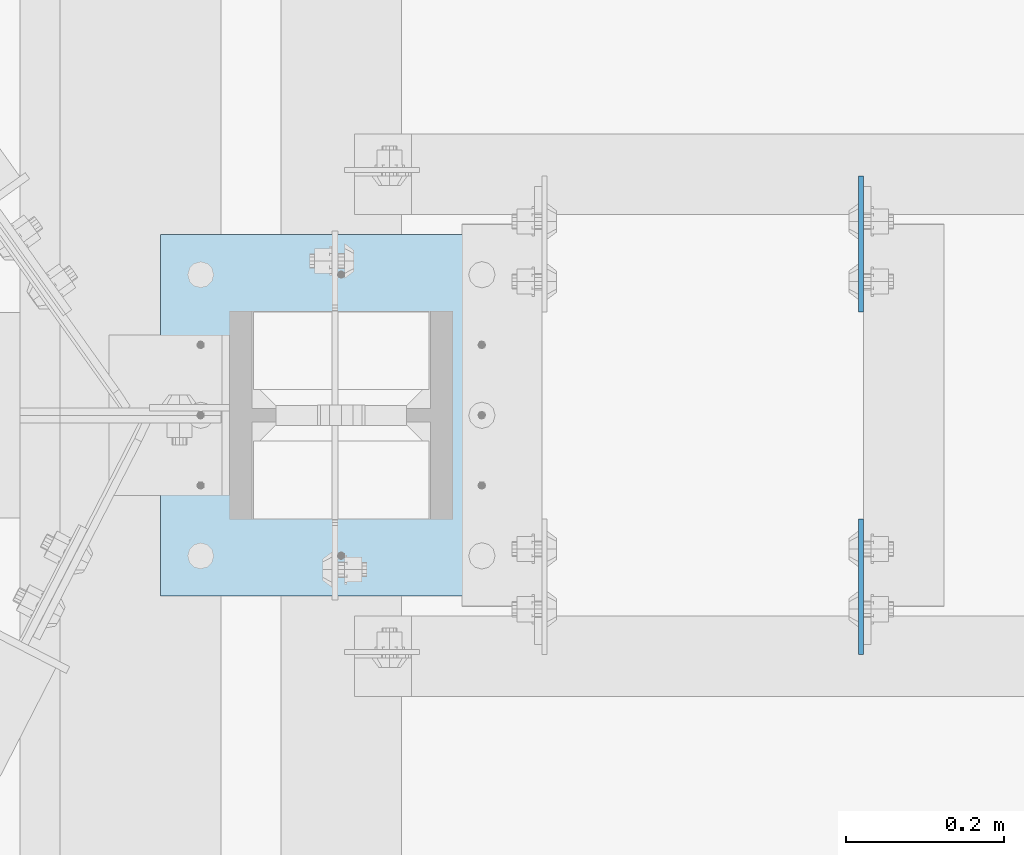
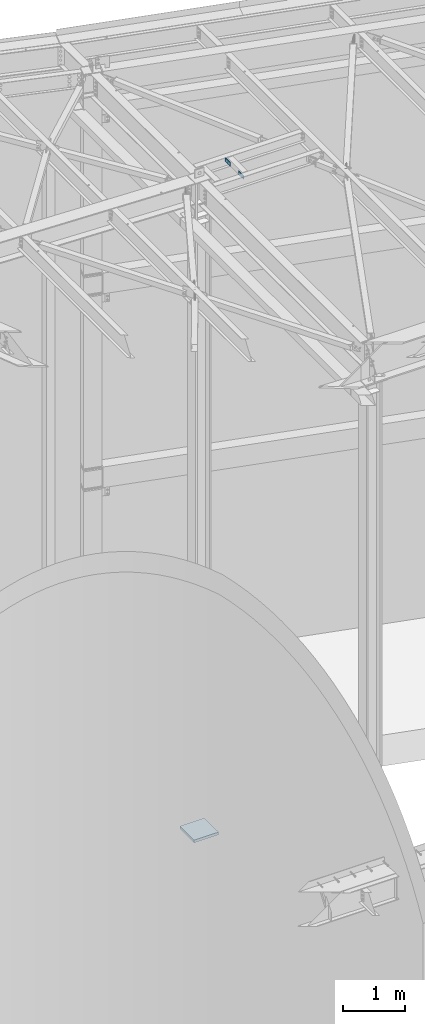
# One storey, part 1662 of 1763: 3 plates, 3 elements without a shape of their own.
"""IFC2X3 building model written with IfcOpenShell, lengths in millimetres."""

from ifc_helpers import new_model, si_unit, frame, origin_with_axes, place, context, subcontext, project, spatial, faceted_brep, material, type_object, element, aggregate, save


model = new_model("IFC2X3")

# Units and contexts
model_context = context("Model", 3, precision=1e-05, world=origin_with_axes())
body_context = subcontext(model_context, "Body", "Model", "MODEL_VIEW")
ifc_project = project(units=[si_unit("LENGTHUNIT", "METRE", prefix="MILLI"), si_unit("AREAUNIT", "SQUARE_METRE"), si_unit("VOLUMEUNIT", "CUBIC_METRE"), si_unit("MASSUNIT", "GRAM", prefix="KILO"), si_unit("TIMEUNIT", "SECOND"), si_unit("PLANEANGLEUNIT", "RADIAN"), si_unit("SOLIDANGLEUNIT", "STERADIAN"), si_unit("THERMODYNAMICTEMPERATUREUNIT", "DEGREE_CELSIUS"), si_unit("LUMINOUSINTENSITYUNIT", "LUMEN")], contexts=[model_context])

# Site, building, storey
site_placement = place(None, origin_with_axes())
site = spatial("IfcSite", under=ifc_project, at=site_placement, CompositionType="ELEMENT")
building_placement = place(site_placement, origin_with_axes())
building = spatial("IfcBuilding", under=site, at=building_placement, Name="Undefined", CompositionType="ELEMENT")
storey_placement = place(building_placement, origin_with_axes())
storey = spatial("IfcBuildingStorey", under=building, at=storey_placement, Name="Undefined", CompositionType="ELEMENT", Elevation=0.0)

# Assembly, plate
assembly_1_placement = place(storey_placement, origin_with_axes())
assembly_1 = element("IfcElementAssembly", 1, at=assembly_1_placement, inside=storey, Name="BEAM", AssemblyPlace="NOTDEFINED", PredefinedType="RIGID_FRAME")
ifc_material = material(Name="STEEL/A36")
plate_type_1 = type_object("IfcPlateType", PredefinedType="NOTDEFINED")
plate_1_placement = place(assembly_1_placement, frame((-39015.0646174483, 63503.96875, 12420.6), z_axis=(0.0, -1.0, 0.0), x_axis=(0.0, 0.0, -1.0)))
plate_1 = element("IfcPlate", 2, at=plate_1_placement, type_object=plate_type_1, material=ifc_material, Name="PLATE", context=body_context, shape_type="Brep", body=[
    faceted_brep([(1.81898940354586e-12, -3.17500000000291, 0.0), (0.0, -3.17500000000291, 171.449996948242), (0.0, 3.17500000000291, 171.449996948242), (-1.81898940354586e-12, 3.17499999997381, 0.0), (76.1999969482422, -3.17500000000291, 171.449996948242), (76.1999969482422, 3.17500000000291, 171.449996948242), (76.1999969482422, -3.17500000000291, 0.0), (76.1999969482422, 3.17500000000291, 0.0)], [[[0, 1, 2, 3]], [[1, 4, 5, 2]], [[4, 6, 7, 5]], [[6, 0, 3, 7]], [[5, 7, 3, 2]], [[6, 4, 1, 0]]]),
])
aggregate(assembly_1, [plate_1])

assembly_2_placement = place(storey_placement, origin_with_axes())
assembly_2 = element("IfcElementAssembly", 3, at=assembly_2_placement, inside=storey, Name="BEAM", AssemblyPlace="NOTDEFINED", PredefinedType="RIGID_FRAME")
plate_2_placement = place(assembly_2_placement, frame((-39015.0646174483, 62899.13125, 12420.6), z_axis=(0.0, 1.0, 0.0), x_axis=(0.0, 0.0, -1.0)))
plate_2 = element("IfcPlate", 4, at=plate_2_placement, type_object=plate_type_1, material=ifc_material, Name="PLATE", context=body_context, shape_type="Brep", body=[
    faceted_brep([(1.81898940354586e-12, -3.17500000000291, 0.0), (0.0, -3.17500000000291, 171.449996948242), (0.0, 3.17500000000291, 171.449996948242), (-1.81898940354586e-12, 3.17499999997381, 0.0), (76.1999969482422, -3.17500000000291, 171.449996948242), (76.1999969482422, 3.17500000000291, 171.449996948242), (76.1999969482422, -3.17500000000291, 0.0), (76.1999969482422, 3.17500000000291, 0.0)], [[[0, 1, 2, 3]], [[1, 4, 5, 2]], [[4, 6, 7, 5]], [[6, 0, 3, 7]], [[5, 7, 3, 2]], [[6, 4, 1, 0]]]),
])
aggregate(assembly_2, [plate_2])

assembly_3_placement = place(storey_placement, origin_with_axes())
assembly_3 = element("IfcElementAssembly", 5, at=assembly_3_placement, inside=storey, Name="COLUMN", AssemblyPlace="NOTDEFINED", PredefinedType="RIGID_FRAME")
plate_type_2 = type_object("IfcPlateType", PredefinedType="NOTDEFINED")
plate_3_placement = place(assembly_3_placement, frame((-39900.8896174484, 62972.95, -393.700000000011), z_axis=(0.0, 1.0, 0.0), x_axis=(1.0, 0.0, 0.0)))
plate_3 = element("IfcPlate", 6, at=plate_3_placement, type_object=plate_type_2, material=ifc_material, Name="PLATE", context=body_context, shape_type="Brep", body=[
    faceted_brep([(0.0, -25.4000000000015, 0.0), (0.0, -25.4, 457.200012207031), (0.0, 25.4, 457.200012207031), (0.0, 25.4000000000015, 0.0), (457.200012207031, -25.4, 457.200012207031), (457.200012207031, 25.4, 457.200012207031), (457.200012207031, -25.4, 0.0), (457.200012207031, 25.4, 0.0)], [[[0, 1, 2, 3]], [[1, 4, 5, 2]], [[4, 6, 7, 5]], [[6, 0, 3, 7]], [[5, 7, 3, 2]], [[6, 4, 1, 0]]]),
])
aggregate(assembly_3, [plate_3])

save(model, "model.ifc")
